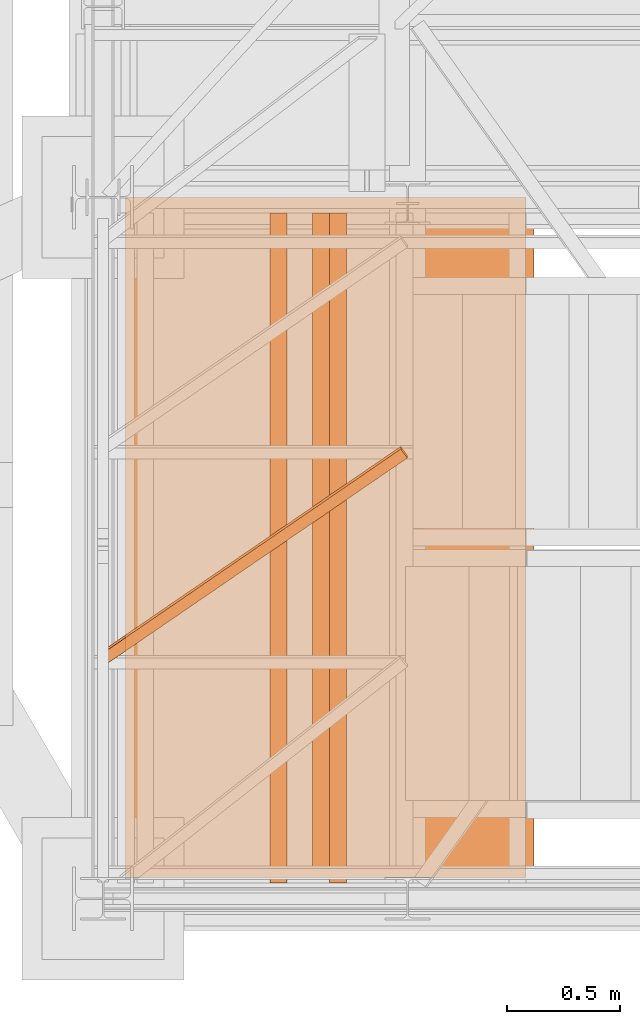
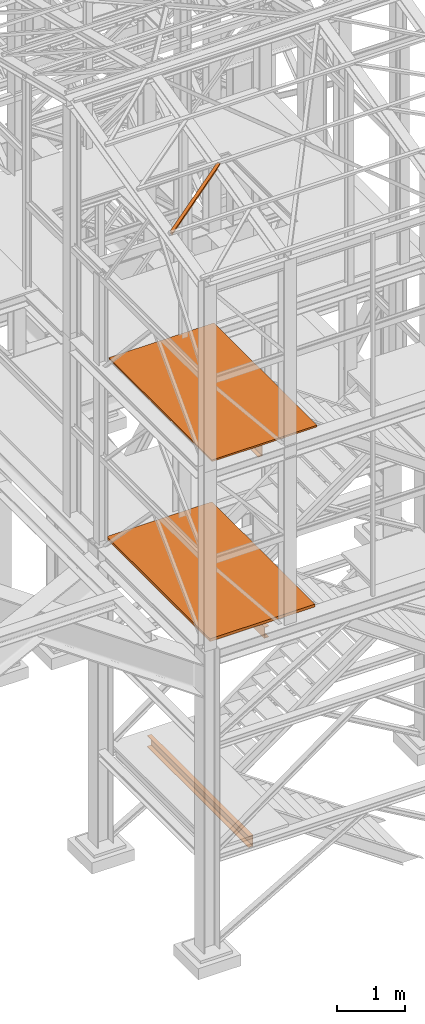
# One storey, part 9 of 208: 6 proxies.
"""IFC2X3 building model written with IfcOpenShell, lengths in millimetres."""

import ifcopenshell
import ifcopenshell.guid

model = None  # the IFC model being written
_history = None  # IfcOwnerHistory: only IFC2X3 demands one
_inside = {}  # id of a spatial element -> (the spatial element, [elements in it])
_under = {}  # id of a project, library or spatial element -> (it, [spatial elements below it])
_declared = {}  # id of a project -> (the project, [libraries it declares])
_typed = {}  # id of a type object -> (the type object, [elements of that type])
_made_of = {}  # id of a material, layer set ... -> (it, [elements and type objects made of it])


def new_model(schema):
    """Start an empty IFC model of exactly this schema.

    Asked for "IFC4X3", IfcOpenShell would pick the latest addendum, in which some entities
    have other attributes; the version numbers below select the first issue.
    IFC2X3 requires an IfcOwnerHistory on every rooted entity: one is made here for all.
    """
    global model, _history
    if schema == "IFC4X3":
        model = ifcopenshell.file(schema_version=(4, 3, 0, 0))
    else:
        model = ifcopenshell.file(schema=schema)
    _inside.clear()
    _under.clear()
    _declared.clear()
    _typed.clear()
    _made_of.clear()
    _history = None
    if model.schema == "IFC2X3":
        org = make("IfcOrganization", Name="unknown")
        user = make(
            "IfcPersonAndOrganization",
            ThePerson=make("IfcPerson", FamilyName="unknown"),
            TheOrganization=org,
        )
        app = make(
            "IfcApplication",
            ApplicationDeveloper=org,
            Version="unknown",
            ApplicationFullName="unknown",
            ApplicationIdentifier="unknown",
        )
        _history = make(
            "IfcOwnerHistory",
            OwningUser=user,
            OwningApplication=app,
            ChangeAction="ADDED",
            CreationDate=0,
        )
    return model


def make(cls, **values):
    """One entity of the class cls with the attributes given. An attribute that is None is left unset."""
    return model.create_entity(
        cls, **{name: value for name, value in values.items() if value is not None}
    )


def entity(cls, *values):
    """Any entity or typed value of the class cls, its attributes in the order of the schema. None: left unset."""
    e = model.create_entity(cls)
    for i, value in enumerate(values):
        if value is not None:
            e[i] = value
    return e


def rooted(cls, **values):
    """An entity with a GlobalId (a new one), such as an element, a storey or a relation."""
    return make(cls, GlobalId=ifcopenshell.guid.new(), OwnerHistory=_history, **values)


def si_unit(unit_type, name, prefix=None):
    """IfcSIUnit, for example si_unit("LENGTHUNIT", "METRE", prefix="MILLI")."""
    return make("IfcSIUnit", UnitType=unit_type, Prefix=prefix, Name=name)


def converted_unit(unit_type, name, factor, base, dimensions=None, offset=None):
    """IfcConversionBasedUnit, such as the inch: factor (a typed value) times the base unit."""
    return make(
        "IfcConversionBasedUnit"
        if offset is None
        else "IfcConversionBasedUnitWithOffset",
        ConversionOffset=offset,
        Dimensions=None
        if dimensions is None
        else entity("IfcDimensionalExponents", *dimensions),
        UnitType=unit_type,
        Name=name,
        ConversionFactor=make(
            "IfcMeasureWithUnit", ValueComponent=factor, UnitComponent=base
        ),
    )


def assignment(units):
    """IfcUnitAssignment: the units of a project."""
    return None if units is None else make("IfcUnitAssignment", Units=units)


def point(xyz):
    """IfcCartesianPoint."""
    return None if xyz is None else make("IfcCartesianPoint", Coordinates=xyz)


def direction(xyz):
    """IfcDirection."""
    return None if xyz is None else make("IfcDirection", DirectionRatios=xyz)


def frame(location, z_axis=None, x_axis=None):
    """IfcAxis2Placement3D, a coordinate frame: its origin and axes. An axis left out is left unset."""
    return make(
        "IfcAxis2Placement3D",
        Location=point(location),
        Axis=direction(z_axis),
        RefDirection=direction(x_axis),
    )


def origin():
    """The frame at (0, 0, 0) with its axes left unset."""
    return frame((0.0, 0.0, 0.0))


def origin_with_axes():
    """The frame at (0, 0, 0) with the z axis (0, 0, 1) and the x axis (1, 0, 0) written out."""
    return frame((0.0, 0.0, 0.0), z_axis=(0.0, 0.0, 1.0), x_axis=(1.0, 0.0, 0.0))


def place(relative_to, where):
    """IfcLocalPlacement: puts the frame where relative to a parent placement (None: the world)."""
    return make(
        "IfcLocalPlacement", PlacementRelTo=relative_to, RelativePlacement=where
    )


def context(
    kind, dimensions, precision=None, world=None, true_north=None, identifier=None
):
    """IfcGeometricRepresentationContext, for example the 3D "Model" context."""
    return make(
        "IfcGeometricRepresentationContext",
        ContextIdentifier=identifier,
        ContextType=kind,
        CoordinateSpaceDimension=dimensions,
        Precision=precision,
        WorldCoordinateSystem=world,
        TrueNorth=true_north,
    )


def subcontext(parent, identifier, kind, view, scale=None):
    """IfcGeometricRepresentationSubContext, for example "Body" below "Model"."""
    return make(
        "IfcGeometricRepresentationSubContext",
        ContextIdentifier=identifier,
        ContextType=kind,
        ParentContext=parent,
        TargetScale=scale,
        TargetView=view,
    )


def project(units=None, contexts=None):
    """IfcProject with its units and contexts."""
    return rooted(
        "IfcProject",
        Name="project",
        RepresentationContexts=contexts,
        UnitsInContext=assignment(units),
    )


def spatial(cls, under=None, at=None, **own):
    """A site, building, storey or space (cls), placed at a placement, below another one or the project."""
    s = rooted(cls, ObjectPlacement=at, **own)
    if under is not None:
        _under.setdefault(under.id(), (under, []))[1].append(s)
    return s


def faces_of(points, faces, orient=None, outer=None):
    """IfcFace entities. A face is a list of loops; a loop is a list of indices into points, from 0.

    orient and outer hold one flag for each loop. By default every Orientation is true, the
    first loop of a face is its IfcFaceOuterBound and the others are IfcFaceBound.
    """
    made = []
    for i, loops in enumerate(faces):
        bounds = []
        for j, loop in enumerate(loops):
            is_outer = j == 0 if outer is None else outer[i][j]
            bounds.append(
                make(
                    "IfcFaceOuterBound" if is_outer else "IfcFaceBound",
                    Bound=make("IfcPolyLoop", Polygon=[points[k] for k in loop]),
                    Orientation=True if orient is None else orient[i][j],
                )
            )
        made.append(make("IfcFace", Bounds=bounds))
    return made


def faceted_brep(points, faces, orient=None, outer=None, voids=None):
    """IfcFacetedBrep: a solid bounded by flat faces; with voids (closed shells), ...WithVoids."""
    shared = [point(p) for p in points]
    hull = make("IfcClosedShell", CfsFaces=faces_of(shared, faces, orient, outer))
    if voids is None:
        return make("IfcFacetedBrep", Outer=hull)
    return make(
        "IfcFacetedBrepWithVoids",
        Outer=hull,
        Voids=[
            make(cls, CfsFaces=faces_of(shared, fs, o, b)) for cls, fs, o, b in voids
        ],
    )


def shape(context_of_items, identifier, shape_type, items):
    """IfcShapeRepresentation: the items that make up one representation, for example the "Body"."""
    return make(
        "IfcShapeRepresentation",
        ContextOfItems=context_of_items,
        RepresentationIdentifier=identifier,
        RepresentationType=shape_type,
        Items=items,
    )


def made_of(thing, what):
    """Note that an element or type object is made of a material, layer set ...; save() writes the relation."""
    if what is not None:
        _made_of.setdefault(what.id(), (what, []))[1].append(thing)
    return thing


def element(
    cls,
    number,
    at=None,
    inside=None,
    cuts=None,
    type_object=None,
    material=None,
    context=None,
    identifier="Body",
    shape_type=None,
    held_by="IfcProductDefinitionShape",
    body=None,
    shapes=None,
    **own,
):
    """One element of the class cls, such as IfcWall. Its Tag is "e" and its number.

    at: its placement. inside: the storey or other place that contains it. cuts: it is an
    opening in that element (IfcRelVoidsElement). A single representation is given by context,
    identifier, shape_type and body (its items); several are given by shapes. held_by: the class
    of the entity that holds the representations. save() writes the other relations.
    """
    e = rooted(cls, Tag="e%d" % number, ObjectPlacement=at, **own)
    if body is not None:
        shapes = [shape(context, identifier, shape_type, body)]
    if shapes is not None:
        e.Representation = make(held_by, Representations=shapes)
    if inside is not None:
        _inside.setdefault(inside.id(), (inside, []))[1].append(e)
    if cuts is not None:
        rooted(
            "IfcRelVoidsElement", RelatingBuildingElement=cuts, RelatedOpeningElement=e
        )
    if type_object is not None:
        _typed.setdefault(type_object.id(), (type_object, []))[1].append(e)
    return made_of(e, material)


def aggregate(whole, parts):
    """IfcRelAggregates: a whole, such as a stair, and the parts it consists of."""
    return rooted("IfcRelAggregates", RelatingObject=whole, RelatedObjects=parts)


def save(model, path):
    """Write the relations noted so far, then the file.

    IfcRelAggregates (storeys below a building ...), IfcRelContainedInSpatialStructure (elements
    in a storey), IfcRelDefinesByType, IfcRelAssociatesMaterial and IfcRelDeclares: one each for
    every whole, place, type object, material and project.
    """
    for whole, parts in _under.values():
        aggregate(whole, parts)
    for where, things in _inside.values():
        rooted(
            "IfcRelContainedInSpatialStructure",
            RelatedElements=things,
            RelatingStructure=where,
        )
    for kind, things in _typed.values():
        rooted("IfcRelDefinesByType", RelatedObjects=things, RelatingType=kind)
    for what, things in _made_of.values():
        rooted("IfcRelAssociatesMaterial", RelatedObjects=things, RelatingMaterial=what)
    for by, libraries in _declared.values():
        rooted("IfcRelDeclares", RelatingContext=by, RelatedDefinitions=libraries)
    model.write(path)


model = new_model("IFC2X3")

# Units and contexts
model_context = context("Model", 3, precision=1e-05, world=origin())
plan_context = context("Plan", 3, precision=1e-05, world=origin())
body_context = subcontext(model_context, "Body", "Model", "MODEL_VIEW")
ifc_project = project(units=[si_unit("LENGTHUNIT", "METRE", prefix="MILLI"), converted_unit("PLANEANGLEUNIT", "DEGREE", entity("IfcPlaneAngleMeasure", 0.0174532925199433), si_unit("PLANEANGLEUNIT", "RADIAN"), dimensions=[0, 0, 0, 0, 0, 0, 0]), si_unit("AREAUNIT", "SQUARE_METRE"), si_unit("VOLUMEUNIT", "CUBIC_METRE")], contexts=[model_context, plan_context])

# Building, storey
building_placement = place(None, origin())
building = spatial("IfcBuilding", under=ifc_project, at=building_placement, CompositionType="COMPLEX")
storey_placement = place(building_placement, origin_with_axes())
storey = spatial("IfcBuildingStorey", under=building, at=storey_placement, Name="Geschoss", CompositionType="ELEMENT")

# Proxies
proxy_1_placement = place(storey_placement, frame((1298.254970018781, -25077.57437538435, 5284.990005364416), z_axis=(0.0, 0.0, 1.0), x_axis=(1.0, 0.0, 0.0)))
element("IfcBuildingElementProxy", 1, at=proxy_1_placement, inside=storey, context=body_context, shape_type="Brep", body=[
    faceted_brep([(0.009999999999990905, 0.00999999999839929, 0.01000000000021828), (1774.863558778435, 0.00999999999839929, 0.01000000000021828), (1774.863558778435, 3015.009985066463, 0.01000000000021828), (0.009999999999990905, 3015.009985066463, 0.01000000000021828), (1774.863558778435, 0.00999999999839929, 50.01000000000022), (0.009999999999990905, 0.00999999999839929, 50.01000000000022), (0.009999999999990905, 3015.009985066463, 50.01000000000022), (1774.863558778435, 3015.009985066463, 50.01000000000022), (1774.863558778435, 0.00999999999839929, 0.01000000000021828), (0.009999999999990905, 0.00999999999839929, 0.01000000000021828), (0.009999999999990905, 0.00999999999839929, 50.01000000000022), (1774.863558778435, 0.00999999999839929, 50.01000000000022), (1774.863558778435, 3015.009985066463, 0.01000000000021828), (1774.863558778435, 0.00999999999839929, 0.01000000000021828), (1774.863558778435, 0.00999999999839929, 50.01000000000022), (1774.863558778435, 3015.009985066463, 50.01000000000022), (0.009999999999990905, 3015.009985066463, 0.01000000000021828), (1774.863558778435, 3015.009985066463, 0.01000000000021828), (1774.863558778435, 3015.009985066463, 50.01000000000022), (0.009999999999990905, 3015.009985066463, 50.01000000000022), (0.009999999999990905, 0.00999999999839929, 0.01000000000021828), (0.009999999999990905, 3015.009985066463, 0.01000000000021828), (0.009999999999990905, 3015.009985066463, 50.01000000000022), (0.009999999999990905, 0.00999999999839929, 50.01000000000022)], [[[0, 1, 2, 3]], [[4, 5, 6, 7]], [[8, 9, 10, 11]], [[12, 13, 14, 15]], [[16, 17, 18, 19]], [[20, 21, 22, 23]]], orient=[[False], [False], [False], [False], [False], [False]]),
])
proxy_2_placement = place(storey_placement, frame((1333.25497001878, -25077.57437538435, 8484.990002086157), z_axis=(0.0, 0.0, 1.0), x_axis=(1.0, 0.0, 0.0)))
element("IfcBuildingElementProxy", 2, at=proxy_2_placement, inside=storey, context=body_context, shape_type="Brep", body=[
    faceted_brep([(0.009999999999990905, 0.00999999999839929, 0.01000000000021828), (1774.863558778435, 0.00999999999839929, 0.01000000000021828), (1774.863558778435, 3015.009985066463, 0.01000000000021828), (0.009999999999990905, 3015.009985066463, 0.01000000000021828), (1774.863558778435, 0.00999999999839929, 30.01000000000022), (0.009999999999990905, 0.00999999999839929, 30.01000000000022), (0.009999999999990905, 3015.009985066463, 30.01000000000022), (1774.863558778435, 3015.009985066463, 30.01000000000022), (1774.863558778435, 0.00999999999839929, 0.01000000000021828), (0.009999999999990905, 0.00999999999839929, 0.01000000000021828), (0.009999999999990905, 0.00999999999839929, 30.01000000000022), (1774.863558778435, 0.00999999999839929, 30.01000000000022), (1774.863558778435, 3015.009985066463, 0.01000000000021828), (1774.863558778435, 0.00999999999839929, 0.01000000000021828), (1774.863558778435, 0.00999999999839929, 30.01000000000022), (1774.863558778435, 3015.009985066463, 30.01000000000022), (0.009999999999990905, 3015.009985066463, 0.01000000000021828), (1774.863558778435, 3015.009985066463, 0.01000000000021828), (1774.863558778435, 3015.009985066463, 30.01000000000022), (0.009999999999990905, 3015.009985066463, 30.01000000000022), (0.009999999999990905, 0.00999999999839929, 0.01000000000021828), (0.009999999999990905, 3015.009985066463, 0.01000000000021828), (0.009999999999990905, 3015.009985066463, 30.01000000000022), (0.009999999999990905, 0.00999999999839929, 30.01000000000022)], [[[0, 1, 2, 3]], [[4, 5, 6, 7]], [[8, 9, 10, 11]], [[12, 13, 14, 15]], [[16, 17, 18, 19]], [[20, 21, 22, 23]]], orient=[[False], [False], [False], [False], [False], [False]]),
])
proxy_3_placement = place(storey_placement, frame((1209.754965757053, -24134.74431075612, 11987.74979641016), z_axis=(0.0, 0.0, 1.0), x_axis=(1.0, 0.0, 0.0)))
element("IfcBuildingElementProxy", 3, at=proxy_3_placement, inside=storey, context=body_context, shape_type="Brep", body=[
    faceted_brep([(1308.5389233782, 967.7692788621098, 232.0521250666225), (1337.349720073477, 928.0575343349883, 222.4128647010039), (1337.349720073477, 916.2634686381534, 271.0019582749592), (1308.5389233782, 955.9752131652713, 280.6412186405796), (0.009999999999990905, 71.25499243027662, 14.44056628674844), (1308.5389233782, 967.7692788621098, 232.0521250666225), (1308.5389233782, 955.9752131652713, 280.6412186405796), (0.009999999999990905, 59.46092673344174, 63.02965986070558), (0.009999999999990905, 11.80406569684055, 0.01000000000021828), (1337.349720073477, 928.0575343349883, 222.4128647010039), (1308.5389233782, 967.7692788621098, 232.0521250666225), (0.009999999999990905, 71.25499243027662, 14.44056628674844), (0.009999999999990905, 0.01000000000203727, 48.59909357395554), (1337.349720073477, 916.2634686381534, 271.0019582749592), (1337.349720073477, 928.0575343349883, 222.4128647010039), (0.009999999999990905, 11.80406569684055, 0.01000000000021828), (0.009999999999990905, 59.46092673344174, 63.02965986070558), (1308.5389233782, 955.9752131652713, 280.6412186405796), (1337.349720073477, 916.2634686381534, 271.0019582749592), (0.009999999999990905, 0.01000000000203727, 48.59909357395554), (0.009999999999990905, 71.25499243027662, 14.44056628674844), (0.009999999999990905, 59.46092673344174, 63.02965986070558), (0.009999999999990905, 0.01000000000203727, 48.59909357395554), (0.009999999999990905, 11.80406569684055, 0.01000000000021828)], [[[0, 1, 2, 3]], [[4, 5, 6, 7]], [[8, 9, 10, 11]], [[12, 13, 14, 15]], [[16, 17, 18, 19]], [[20, 21, 22, 23]]], orient=[[False], [False], [False], [False], [False], [False]]),
])
proxy_4_placement = place(storey_placement, frame((2203.147800204686, -25102.57439001986, 5042.595014998486), z_axis=(0.0, 0.0, 1.0), x_axis=(1.0, 0.0, 0.0)))
element("IfcBuildingElementProxy", 4, at=proxy_4_placement, inside=storey, context=body_context, shape_type="Brep", body=[
    faceted_brep([(0.01000000000021828, 2970.009999403952, 200.0100029802325), (0.01000000000021828, 2970.009999403952, 0.01000000000021828), (75.01000111758731, 2970.009999403952, 0.01000000000021828), (75.01000111758731, 2970.009999403952, 2.97083092689536), (73.89400100171588, 2970.009999403952, 7.368834147453526), (69.48847269475482, 2970.009999403952, 8.951724896431188), (19.09293180167697, 2970.009999403952, 12.98336816787742), (13.35380079060815, 2970.009999403952, 14.57858962774299), (9.50015002697728, 2970.009999403952, 18.85888857603095), (8.510000461936215, 2970.009999403952, 24.44674206733725), (8.510000461936215, 2970.009999403952, 175.5732609128954), (9.50015002697728, 2970.009999403952, 181.1611144042017), (13.35380079060815, 2970.009999403952, 185.4414133524897), (19.09293180167697, 2970.009999403952, 187.0366348123553), (69.48847269475482, 2970.009999403952, 191.0682780838015), (73.89400100171588, 2970.009999403952, 192.6511688327792), (75.01000111758731, 2970.009999403952, 197.0491720533373), (75.01000111758731, 2970.009999403952, 200.0100029802325), (0.01000000000021828, 2970.009999403952, 0.01000000000021828), (0.01000000000021828, 2970.009999403952, 200.0100029802325), (0.01000000000021828, 0.01000000000203727, 200.0100029802325), (0.01000000000021828, 0.01000000000203727, 0.01000000000021828), (75.01000111758731, 2970.009999403952, 0.01000000000021828), (0.01000000000021828, 2970.009999403952, 0.01000000000021828), (0.01000000000021828, 0.01000000000203727, 0.01000000000021828), (75.01000111758731, 0.01000000000203727, 0.01000000000021828), (75.01000111758731, 2970.009999403952, 2.97083092689536), (75.01000111758731, 2970.009999403952, 0.01000000000021828), (75.01000111758731, 0.01000000000203727, 0.01000000000021828), (75.01000111758731, 0.01000000000203727, 2.97083092689536), (73.89400100171588, 2970.009999403952, 7.368834147453526), (75.01000111758731, 2970.009999403952, 2.97083092689536), (75.01000111758731, 0.01000000000203727, 2.97083092689536), (73.89400100171588, 0.01000000000203727, 7.368834147453526), (69.48847269475482, 2970.009999403952, 8.951724896431188), (73.89400100171588, 2970.009999403952, 7.368834147453526), (73.89400100171588, 0.01000000000203727, 7.368834147453526), (69.48847269475482, 0.01000000000203727, 8.951724896431188), (19.09293180167697, 2970.009999403952, 12.98336816787742), (69.48847269475482, 2970.009999403952, 8.951724896431188), (69.48847269475482, 0.01000000000203727, 8.951724896431188), (19.09293180167697, 0.01000000000203727, 12.98336816787742), (13.35380079060815, 2970.009999403952, 14.57858962774299), (19.09293180167697, 2970.009999403952, 12.98336816787742), (19.09293180167697, 0.01000000000203727, 12.98336816787742), (13.35380079060815, 0.01000000000203727, 14.57858962774299), (9.50015002697728, 2970.009999403952, 18.85888857603095), (13.35380079060815, 2970.009999403952, 14.57858962774299), (13.35380079060815, 0.01000000000203727, 14.57858962774299), (9.50015002697728, 0.01000000000203727, 18.85888857603095), (8.510000461936215, 2970.009999403952, 24.44674206733725), (9.50015002697728, 2970.009999403952, 18.85888857603095), (9.50015002697728, 0.01000000000203727, 18.85888857603095), (8.510000461936215, 0.01000000000203727, 24.44674206733725), (8.510000461936215, 2970.009999403952, 175.5732609128954), (8.510000461936215, 2970.009999403952, 24.44674206733725), (8.510000461936215, 0.01000000000203727, 24.44674206733725), (8.510000461936215, 0.01000000000203727, 175.5732609128954), (9.50015002697728, 2970.009999403952, 181.1611144042017), (8.510000461936215, 2970.009999403952, 175.5732609128954), (8.510000461936215, 0.01000000000203727, 175.5732609128954), (9.50015002697728, 0.01000000000203727, 181.1611144042017), (13.35380079060815, 2970.009999403952, 185.4414133524897), (9.50015002697728, 2970.009999403952, 181.1611144042017), (9.50015002697728, 0.01000000000203727, 181.1611144042017), (13.35380079060815, 0.01000000000203727, 185.4414133524897), (19.09293180167697, 2970.009999403952, 187.0366348123553), (13.35380079060815, 2970.009999403952, 185.4414133524897), (13.35380079060815, 0.01000000000203727, 185.4414133524897), (19.09293180167697, 0.01000000000203727, 187.0366348123553), (69.48847269475482, 2970.009999403952, 191.0682780838015), (19.09293180167697, 2970.009999403952, 187.0366348123553), (19.09293180167697, 0.01000000000203727, 187.0366348123553), (69.48847269475482, 0.01000000000203727, 191.0682780838015), (73.89400100171588, 2970.009999403952, 192.6511688327792), (69.48847269475482, 2970.009999403952, 191.0682780838015), (69.48847269475482, 0.01000000000203727, 191.0682780838015), (73.89400100171588, 0.01000000000203727, 192.6511688327792), (75.01000111758731, 2970.009999403952, 197.0491720533373), (73.89400100171588, 2970.009999403952, 192.6511688327792), (73.89400100171588, 0.01000000000203727, 192.6511688327792), (75.01000111758731, 0.01000000000203727, 197.0491720533373), (75.01000111758731, 2970.009999403952, 200.0100029802325), (75.01000111758731, 2970.009999403952, 197.0491720533373), (75.01000111758731, 0.01000000000203727, 197.0491720533373), (75.01000111758731, 0.01000000000203727, 200.0100029802325), (0.01000000000021828, 2970.009999403952, 200.0100029802325), (75.01000111758731, 2970.009999403952, 200.0100029802325), (75.01000111758731, 0.01000000000203727, 200.0100029802325), (0.01000000000021828, 0.01000000000203727, 200.0100029802325), (0.01000000000021828, 0.01000000000203727, 200.0100029802325), (75.01000111758731, 0.01000000000203727, 200.0100029802325), (75.01000111758731, 0.01000000000203727, 197.0491720533373), (73.89400100171588, 0.01000000000203727, 192.6511688327792), (69.48847269475482, 0.01000000000203727, 191.0682780838015), (19.09293180167697, 0.01000000000203727, 187.0366348123553), (13.35380079060815, 0.01000000000203727, 185.4414133524897), (9.50015002697728, 0.01000000000203727, 181.1611144042017), (8.510000461936215, 0.01000000000203727, 175.5732609128954), (8.510000461936215, 0.01000000000203727, 24.44674206733725), (9.50015002697728, 0.01000000000203727, 18.85888857603095), (13.35380079060815, 0.01000000000203727, 14.57858962774299), (19.09293180167697, 0.01000000000203727, 12.98336816787742), (69.48847269475482, 0.01000000000203727, 8.951724896431188), (73.89400100171588, 0.01000000000203727, 7.368834147453526), (75.01000111758731, 0.01000000000203727, 2.97083092689536), (75.01000111758731, 0.01000000000203727, 0.01000000000021828), (0.01000000000021828, 0.01000000000203727, 0.01000000000021828)], [[[0, 1, 2, 3, 4, 5, 6, 7, 8, 9, 10, 11, 12, 13, 14, 15, 16, 17]], [[18, 19, 20, 21]], [[22, 23, 24, 25]], [[26, 27, 28, 29]], [[30, 31, 32, 33]], [[34, 35, 36, 37]], [[38, 39, 40, 41]], [[42, 43, 44, 45]], [[46, 47, 48, 49]], [[50, 51, 52, 53]], [[54, 55, 56, 57]], [[58, 59, 60, 61]], [[62, 63, 64, 65]], [[66, 67, 68, 69]], [[70, 71, 72, 73]], [[74, 75, 76, 77]], [[78, 79, 80, 81]], [[82, 83, 84, 85]], [[86, 87, 88, 89]], [[90, 91, 92, 93, 94, 95, 96, 97, 98, 99, 100, 101, 102, 103, 104, 105, 106, 107]]], orient=[[False], [False], [False], [False], [False], [False], [False], [False], [False], [False], [False], [False], [False], [False], [False], [False], [False], [False], [False], [False]]),
])
proxy_5_placement = place(storey_placement, frame((1937.992776043087, -25102.57439001986, 1399.989998075481), z_axis=(0.0, 0.0, 1.0), x_axis=(1.0, 0.0, 0.0)))
element("IfcBuildingElementProxy", 5, at=proxy_5_placement, inside=storey, context=body_context, shape_type="Brep", body=[
    faceted_brep([(75.01000111758708, 2970.009999403952, 200.0100029802322), (0.009999999999990905, 2970.009999403952, 200.0100029802322), (0.009999999999990905, 2970.009999403952, 197.0491720533371), (1.12600011587142, 2970.009999403952, 192.6511688327789), (5.53152842283248, 2970.009999403952, 191.0682780838013), (55.92706931591033, 2970.009999403952, 187.036634812355), (61.66620032697915, 2970.009999403952, 185.4414133524895), (65.51985109061002, 2970.009999403952, 181.1611144042015), (66.51000065565108, 2970.009999403952, 175.5732609128952), (66.51000065565108, 2970.009999403952, 24.44674206733703), (65.51985109061002, 2970.009999403952, 18.85888857603072), (61.66620032697915, 2970.009999403952, 14.57858962774276), (55.92706931591033, 2970.009999403952, 12.98336816787719), (5.53152842283248, 2970.009999403952, 8.95172489643096), (1.12600011587142, 2970.009999403952, 7.368834147453299), (0.009999999999990905, 2970.009999403952, 2.970830926895133), (0.009999999999990905, 2970.009999403952, 0.009999999999990905), (75.01000111758708, 2970.009999403952, 0.009999999999990905), (75.01000111758708, 2970.009999403952, 0.009999999999990905), (75.01000111758708, 0.01000000000203727, 0.009999999999990905), (75.01000111758708, 0.01000000000203727, 200.0100029802322), (75.01000111758708, 2970.009999403952, 200.0100029802322), (0.009999999999990905, 2970.009999403952, 0.009999999999990905), (0.009999999999990905, 0.01000000000203727, 0.009999999999990905), (75.01000111758708, 0.01000000000203727, 0.009999999999990905), (75.01000111758708, 2970.009999403952, 0.009999999999990905), (0.009999999999990905, 2970.009999403952, 2.970830926895133), (0.009999999999990905, 0.01000000000203727, 2.970830926895133), (0.009999999999990905, 0.01000000000203727, 0.009999999999990905), (0.009999999999990905, 2970.009999403952, 0.009999999999990905), (1.12600011587142, 2970.009999403952, 7.368834147453299), (1.12600011587142, 0.01000000000203727, 7.368834147453299), (0.009999999999990905, 0.01000000000203727, 2.970830926895133), (0.009999999999990905, 2970.009999403952, 2.970830926895133), (5.53152842283248, 2970.009999403952, 8.95172489643096), (5.53152842283248, 0.01000000000203727, 8.95172489643096), (1.12600011587142, 0.01000000000203727, 7.368834147453299), (1.12600011587142, 2970.009999403952, 7.368834147453299), (55.92706931591033, 2970.009999403952, 12.98336816787719), (55.92706931591033, 0.01000000000203727, 12.98336816787719), (5.53152842283248, 0.01000000000203727, 8.95172489643096), (5.53152842283248, 2970.009999403952, 8.95172489643096), (61.66620032697915, 2970.009999403952, 14.57858962774276), (61.66620032697915, 0.01000000000203727, 14.57858962774276), (55.92706931591033, 0.01000000000203727, 12.98336816787719), (55.92706931591033, 2970.009999403952, 12.98336816787719), (65.51985109061002, 2970.009999403952, 18.85888857603072), (65.51985109061002, 0.01000000000203727, 18.85888857603072), (61.66620032697915, 0.01000000000203727, 14.57858962774276), (61.66620032697915, 2970.009999403952, 14.57858962774276), (66.51000065565108, 2970.009999403952, 24.44674206733703), (66.51000065565108, 0.01000000000203727, 24.44674206733703), (65.51985109061002, 0.01000000000203727, 18.85888857603072), (65.51985109061002, 2970.009999403952, 18.85888857603072), (66.51000065565108, 2970.009999403952, 175.5732609128952), (66.51000065565108, 0.01000000000203727, 175.5732609128952), (66.51000065565108, 0.01000000000203727, 24.44674206733703), (66.51000065565108, 2970.009999403952, 24.44674206733703), (65.51985109061002, 2970.009999403952, 181.1611144042015), (65.51985109061002, 0.01000000000203727, 181.1611144042015), (66.51000065565108, 0.01000000000203727, 175.5732609128952), (66.51000065565108, 2970.009999403952, 175.5732609128952), (61.66620032697915, 2970.009999403952, 185.4414133524895), (61.66620032697915, 0.01000000000203727, 185.4414133524895), (65.51985109061002, 0.01000000000203727, 181.1611144042015), (65.51985109061002, 2970.009999403952, 181.1611144042015), (55.92706931591033, 2970.009999403952, 187.036634812355), (55.92706931591033, 0.01000000000203727, 187.036634812355), (61.66620032697915, 0.01000000000203727, 185.4414133524895), (61.66620032697915, 2970.009999403952, 185.4414133524895), (5.53152842283248, 2970.009999403952, 191.0682780838013), (5.53152842283248, 0.01000000000203727, 191.0682780838013), (55.92706931591033, 0.01000000000203727, 187.036634812355), (55.92706931591033, 2970.009999403952, 187.036634812355), (1.12600011587142, 2970.009999403952, 192.6511688327789), (1.12600011587142, 0.01000000000203727, 192.6511688327789), (5.53152842283248, 0.01000000000203727, 191.0682780838013), (5.53152842283248, 2970.009999403952, 191.0682780838013), (0.009999999999990905, 2970.009999403952, 197.0491720533371), (0.009999999999990905, 0.01000000000203727, 197.0491720533371), (1.12600011587142, 0.01000000000203727, 192.6511688327789), (1.12600011587142, 2970.009999403952, 192.6511688327789), (0.009999999999990905, 2970.009999403952, 200.0100029802322), (0.009999999999990905, 0.01000000000203727, 200.0100029802322), (0.009999999999990905, 0.01000000000203727, 197.0491720533371), (0.009999999999990905, 2970.009999403952, 197.0491720533371), (75.01000111758708, 2970.009999403952, 200.0100029802322), (75.01000111758708, 0.01000000000203727, 200.0100029802322), (0.009999999999990905, 0.01000000000203727, 200.0100029802322), (0.009999999999990905, 2970.009999403952, 200.0100029802322), (75.01000111758708, 0.01000000000203727, 200.0100029802322), (75.01000111758708, 0.01000000000203727, 0.009999999999990905), (0.009999999999990905, 0.01000000000203727, 0.009999999999990905), (0.009999999999990905, 0.01000000000203727, 2.970830926895133), (1.12600011587142, 0.01000000000203727, 7.368834147453299), (5.53152842283248, 0.01000000000203727, 8.95172489643096), (55.92706931591033, 0.01000000000203727, 12.98336816787719), (61.66620032697915, 0.01000000000203727, 14.57858962774276), (65.51985109061002, 0.01000000000203727, 18.85888857603072), (66.51000065565108, 0.01000000000203727, 24.44674206733703), (66.51000065565108, 0.01000000000203727, 175.5732609128952), (65.51985109061002, 0.01000000000203727, 181.1611144042015), (61.66620032697915, 0.01000000000203727, 185.4414133524895), (55.92706931591033, 0.01000000000203727, 187.036634812355), (5.53152842283248, 0.01000000000203727, 191.0682780838013), (1.12600011587142, 0.01000000000203727, 192.6511688327789), (0.009999999999990905, 0.01000000000203727, 197.0491720533371), (0.009999999999990905, 0.01000000000203727, 200.0100029802322)], [[[0, 1, 2, 3, 4, 5, 6, 7, 8, 9, 10, 11, 12, 13, 14, 15, 16, 17]], [[18, 19, 20, 21]], [[22, 23, 24, 25]], [[26, 27, 28, 29]], [[30, 31, 32, 33]], [[34, 35, 36, 37]], [[38, 39, 40, 41]], [[42, 43, 44, 45]], [[46, 47, 48, 49]], [[50, 51, 52, 53]], [[54, 55, 56, 57]], [[58, 59, 60, 61]], [[62, 63, 64, 65]], [[66, 67, 68, 69]], [[70, 71, 72, 73]], [[74, 75, 76, 77]], [[78, 79, 80, 81]], [[82, 83, 84, 85]], [[86, 87, 88, 89]], [[90, 91, 92, 93, 94, 95, 96, 97, 98, 99, 100, 101, 102, 103, 104, 105, 106, 107]]], orient=[[False], [False], [False], [False], [False], [False], [False], [False], [False], [False], [False], [False], [False], [False], [False], [False], [False], [False], [False], [False]]),
])
proxy_6_placement = place(storey_placement, frame((2126.403736997373, -25052.57438554951, 8269.989998509878), z_axis=(0.0, 0.0, 1.0), x_axis=(1.0, 0.0, 0.0)))
element("IfcBuildingElementProxy", 6, at=proxy_6_placement, inside=storey, context=body_context, shape_type="Brep", body=[
    faceted_brep([(75.01000111758731, 2920.009994933604, 200.0100029802325), (0.01000000000021828, 2920.009994933604, 200.0100029802325), (0.01000000000021828, 2920.009994933604, 197.0491720533373), (1.126000115871648, 2920.009994933604, 192.6511688327792), (5.531528422832707, 2920.009994933604, 191.0682780838015), (55.92706931591056, 2920.009994933604, 187.0366348123553), (61.66620032697938, 2920.009994933604, 185.4414133524897), (65.51985109061025, 2920.009994933604, 181.1611144042017), (66.51000065565131, 2920.009994933604, 175.5732609128954), (66.51000065565131, 2920.009994933604, 24.44674206733725), (65.51985109061025, 2920.009994933604, 18.85888857603095), (61.66620032697938, 2920.009994933604, 14.57858962774299), (55.92706931591056, 2920.009994933604, 12.98336816787742), (5.531528422832707, 2920.009994933604, 8.951724896431188), (1.126000115871648, 2920.009994933604, 7.368834147453526), (0.01000000000021828, 2920.009994933604, 2.97083092689536), (0.01000000000021828, 2920.009994933604, 0.01000000000021828), (75.01000111758731, 2920.009994933604, 0.01000000000021828), (75.01000111758731, 2920.009994933604, 0.01000000000021828), (75.01000111758731, 0.00999999999839929, 0.01000000000021828), (75.01000111758731, 0.00999999999839929, 200.0100029802325), (75.01000111758731, 2920.009994933604, 200.0100029802325), (0.01000000000021828, 2920.009994933604, 0.01000000000021828), (0.01000000000021828, 0.00999999999839929, 0.01000000000021828), (75.01000111758731, 0.00999999999839929, 0.01000000000021828), (75.01000111758731, 2920.009994933604, 0.01000000000021828), (0.01000000000021828, 2920.009994933604, 2.97083092689536), (0.01000000000021828, 0.00999999999839929, 2.97083092689536), (0.01000000000021828, 0.00999999999839929, 0.01000000000021828), (0.01000000000021828, 2920.009994933604, 0.01000000000021828), (1.126000115871648, 2920.009994933604, 7.368834147453526), (1.126000115871648, 0.00999999999839929, 7.368834147453526), (0.01000000000021828, 0.00999999999839929, 2.97083092689536), (0.01000000000021828, 2920.009994933604, 2.97083092689536), (5.531528422832707, 2920.009994933604, 8.951724896431188), (5.531528422832707, 0.00999999999839929, 8.951724896431188), (1.126000115871648, 0.00999999999839929, 7.368834147453526), (1.126000115871648, 2920.009994933604, 7.368834147453526), (55.92706931591056, 2920.009994933604, 12.98336816787742), (55.92706931591056, 0.00999999999839929, 12.98336816787742), (5.531528422832707, 0.00999999999839929, 8.951724896431188), (5.531528422832707, 2920.009994933604, 8.951724896431188), (61.66620032697938, 2920.009994933604, 14.57858962774299), (61.66620032697938, 0.00999999999839929, 14.57858962774299), (55.92706931591056, 0.00999999999839929, 12.98336816787742), (55.92706931591056, 2920.009994933604, 12.98336816787742), (65.51985109061025, 2920.009994933604, 18.85888857603095), (65.51985109061025, 0.00999999999839929, 18.85888857603095), (61.66620032697938, 0.00999999999839929, 14.57858962774299), (61.66620032697938, 2920.009994933604, 14.57858962774299), (66.51000065565131, 2920.009994933604, 24.44674206733725), (66.51000065565131, 0.00999999999839929, 24.44674206733725), (65.51985109061025, 0.00999999999839929, 18.85888857603095), (65.51985109061025, 2920.009994933604, 18.85888857603095), (66.51000065565131, 2920.009994933604, 175.5732609128954), (66.51000065565131, 0.00999999999839929, 175.5732609128954), (66.51000065565131, 0.00999999999839929, 24.44674206733725), (66.51000065565131, 2920.009994933604, 24.44674206733725), (65.51985109061025, 2920.009994933604, 181.1611144042017), (65.51985109061025, 0.00999999999839929, 181.1611144042017), (66.51000065565131, 0.00999999999839929, 175.5732609128954), (66.51000065565131, 2920.009994933604, 175.5732609128954), (61.66620032697938, 2920.009994933604, 185.4414133524897), (61.66620032697938, 0.00999999999839929, 185.4414133524897), (65.51985109061025, 0.00999999999839929, 181.1611144042017), (65.51985109061025, 2920.009994933604, 181.1611144042017), (55.92706931591056, 2920.009994933604, 187.0366348123553), (55.92706931591056, 0.00999999999839929, 187.0366348123553), (61.66620032697938, 0.00999999999839929, 185.4414133524897), (61.66620032697938, 2920.009994933604, 185.4414133524897), (5.531528422832707, 2920.009994933604, 191.0682780838015), (5.531528422832707, 0.00999999999839929, 191.0682780838015), (55.92706931591056, 0.00999999999839929, 187.0366348123553), (55.92706931591056, 2920.009994933604, 187.0366348123553), (1.126000115871648, 2920.009994933604, 192.6511688327792), (1.126000115871648, 0.00999999999839929, 192.6511688327792), (5.531528422832707, 0.00999999999839929, 191.0682780838015), (5.531528422832707, 2920.009994933604, 191.0682780838015), (0.01000000000021828, 2920.009994933604, 197.0491720533373), (0.01000000000021828, 0.00999999999839929, 197.0491720533373), (1.126000115871648, 0.00999999999839929, 192.6511688327792), (1.126000115871648, 2920.009994933604, 192.6511688327792), (0.01000000000021828, 2920.009994933604, 200.0100029802325), (0.01000000000021828, 0.00999999999839929, 200.0100029802325), (0.01000000000021828, 0.00999999999839929, 197.0491720533373), (0.01000000000021828, 2920.009994933604, 197.0491720533373), (75.01000111758731, 2920.009994933604, 200.0100029802325), (75.01000111758731, 0.00999999999839929, 200.0100029802325), (0.01000000000021828, 0.00999999999839929, 200.0100029802325), (0.01000000000021828, 2920.009994933604, 200.0100029802325), (75.01000111758731, 0.00999999999839929, 0.01000000000021828), (0.01000000000021828, 0.00999999999839929, 0.01000000000021828), (0.01000000000021828, 0.00999999999839929, 2.97083092689536), (1.126000115871648, 0.00999999999839929, 7.368834147453526), (5.531528422832707, 0.00999999999839929, 8.951724896431188), (55.92706931591056, 0.00999999999839929, 12.98336816787742), (61.66620032697938, 0.00999999999839929, 14.57858962774299), (65.51985109061025, 0.00999999999839929, 18.85888857603095), (66.51000065565131, 0.00999999999839929, 24.44674206733725), (66.51000065565131, 0.00999999999839929, 175.5732609128954), (65.51985109061025, 0.00999999999839929, 181.1611144042017), (61.66620032697938, 0.00999999999839929, 185.4414133524897), (55.92706931591056, 0.00999999999839929, 187.0366348123553), (5.531528422832707, 0.00999999999839929, 191.0682780838015), (1.126000115871648, 0.00999999999839929, 192.6511688327792), (0.01000000000021828, 0.00999999999839929, 197.0491720533373), (0.01000000000021828, 0.00999999999839929, 200.0100029802325), (75.01000111758731, 0.00999999999839929, 200.0100029802325)], [[[0, 1, 2, 3, 4, 5, 6, 7, 8, 9, 10, 11, 12, 13, 14, 15, 16, 17]], [[18, 19, 20, 21]], [[22, 23, 24, 25]], [[26, 27, 28, 29]], [[30, 31, 32, 33]], [[34, 35, 36, 37]], [[38, 39, 40, 41]], [[42, 43, 44, 45]], [[46, 47, 48, 49]], [[50, 51, 52, 53]], [[54, 55, 56, 57]], [[58, 59, 60, 61]], [[62, 63, 64, 65]], [[66, 67, 68, 69]], [[70, 71, 72, 73]], [[74, 75, 76, 77]], [[78, 79, 80, 81]], [[82, 83, 84, 85]], [[86, 87, 88, 89]], [[90, 91, 92, 93, 94, 95, 96, 97, 98, 99, 100, 101, 102, 103, 104, 105, 106, 107]]], orient=[[False], [False], [False], [False], [False], [False], [False], [False], [False], [False], [False], [False], [False], [False], [False], [False], [False], [False], [False], [False]]),
])

save(model, "model.ifc")
